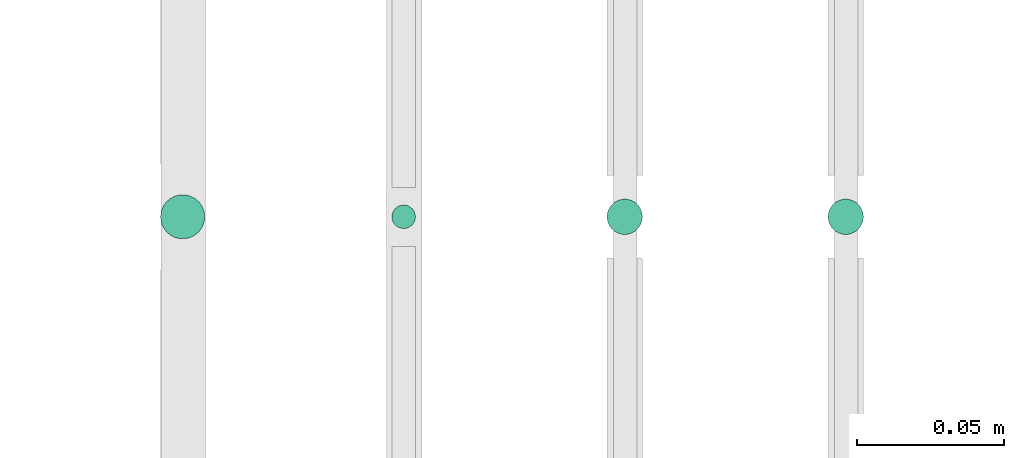
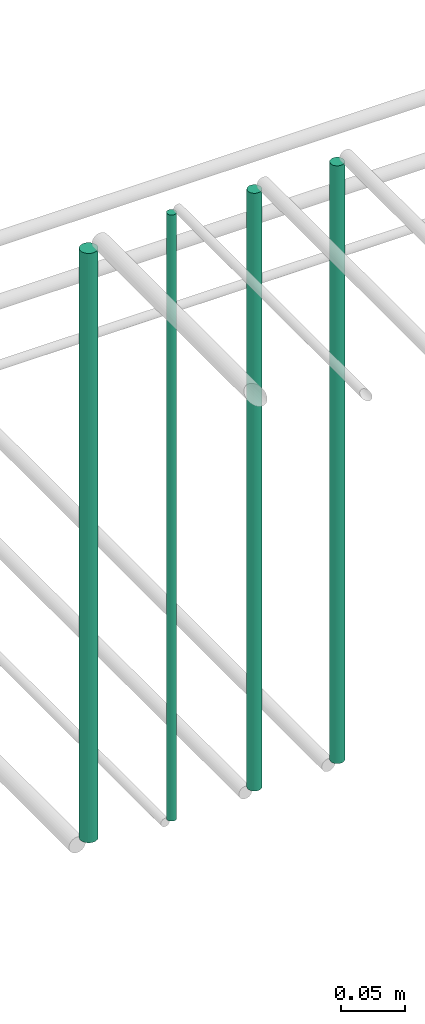
# One storey, part 123 of 331: 4 flow segments.
"""IFC2X3 building model written with IfcOpenShell, lengths in millimetres."""

import ifcopenshell
import ifcopenshell.guid

model = None  # the IFC model being written
_history = None  # IfcOwnerHistory: only IFC2X3 demands one
_inside = {}  # id of a spatial element -> (the spatial element, [elements in it])
_under = {}  # id of a project, library or spatial element -> (it, [spatial elements below it])
_declared = {}  # id of a project -> (the project, [libraries it declares])
_typed = {}  # id of a type object -> (the type object, [elements of that type])
_made_of = {}  # id of a material, layer set ... -> (it, [elements and type objects made of it])


def new_model(schema):
    """Start an empty IFC model of exactly this schema.

    Asked for "IFC4X3", IfcOpenShell would pick the latest addendum, in which some entities
    have other attributes; the version numbers below select the first issue.
    IFC2X3 requires an IfcOwnerHistory on every rooted entity: one is made here for all.
    """
    global model, _history
    if schema == "IFC4X3":
        model = ifcopenshell.file(schema_version=(4, 3, 0, 0))
    else:
        model = ifcopenshell.file(schema=schema)
    _inside.clear()
    _under.clear()
    _declared.clear()
    _typed.clear()
    _made_of.clear()
    _history = None
    if model.schema == "IFC2X3":
        org = make("IfcOrganization", Name="unknown")
        user = make(
            "IfcPersonAndOrganization",
            ThePerson=make("IfcPerson", FamilyName="unknown"),
            TheOrganization=org,
        )
        app = make(
            "IfcApplication",
            ApplicationDeveloper=org,
            Version="unknown",
            ApplicationFullName="unknown",
            ApplicationIdentifier="unknown",
        )
        _history = make(
            "IfcOwnerHistory",
            OwningUser=user,
            OwningApplication=app,
            ChangeAction="ADDED",
            CreationDate=0,
        )
    return model


def make(cls, **values):
    """One entity of the class cls with the attributes given. An attribute that is None is left unset."""
    return model.create_entity(
        cls, **{name: value for name, value in values.items() if value is not None}
    )


def entity(cls, *values):
    """Any entity or typed value of the class cls, its attributes in the order of the schema. None: left unset."""
    e = model.create_entity(cls)
    for i, value in enumerate(values):
        if value is not None:
            e[i] = value
    return e


def rooted(cls, **values):
    """An entity with a GlobalId (a new one), such as an element, a storey or a relation."""
    return make(cls, GlobalId=ifcopenshell.guid.new(), OwnerHistory=_history, **values)


def si_unit(unit_type, name, prefix=None):
    """IfcSIUnit, for example si_unit("LENGTHUNIT", "METRE", prefix="MILLI")."""
    return make("IfcSIUnit", UnitType=unit_type, Prefix=prefix, Name=name)


def converted_unit(unit_type, name, factor, base, dimensions=None, offset=None):
    """IfcConversionBasedUnit, such as the inch: factor (a typed value) times the base unit."""
    return make(
        "IfcConversionBasedUnit"
        if offset is None
        else "IfcConversionBasedUnitWithOffset",
        ConversionOffset=offset,
        Dimensions=None
        if dimensions is None
        else entity("IfcDimensionalExponents", *dimensions),
        UnitType=unit_type,
        Name=name,
        ConversionFactor=make(
            "IfcMeasureWithUnit", ValueComponent=factor, UnitComponent=base
        ),
    )


def derived_unit(unit_type, elements):
    """IfcDerivedUnit: a product of units, each with its exponent."""
    return make(
        "IfcDerivedUnit",
        Elements=[
            make("IfcDerivedUnitElement", Unit=unit, Exponent=power)
            for unit, power in elements
        ],
        UnitType=unit_type,
    )


def assignment(units):
    """IfcUnitAssignment: the units of a project."""
    return None if units is None else make("IfcUnitAssignment", Units=units)


def point(xyz):
    """IfcCartesianPoint."""
    return None if xyz is None else make("IfcCartesianPoint", Coordinates=xyz)


def direction(xyz):
    """IfcDirection."""
    return None if xyz is None else make("IfcDirection", DirectionRatios=xyz)


def frame(location, z_axis=None, x_axis=None):
    """IfcAxis2Placement3D, a coordinate frame: its origin and axes. An axis left out is left unset."""
    return make(
        "IfcAxis2Placement3D",
        Location=point(location),
        Axis=direction(z_axis),
        RefDirection=direction(x_axis),
    )


def frame_2d(location, x_axis=None):
    """IfcAxis2Placement2D, a coordinate frame in the plane: its origin and x axis."""
    return make(
        "IfcAxis2Placement2D", Location=point(location), RefDirection=direction(x_axis)
    )


def origin():
    """The frame at (0, 0, 0) with its axes left unset."""
    return frame((0.0, 0.0, 0.0))


def origin_2d_with_axis():
    """The frame at (0, 0) in the plane with the x axis (1, 0) written out."""
    return frame_2d((0.0, 0.0), x_axis=(1.0, 0.0))


def place(relative_to, where):
    """IfcLocalPlacement: puts the frame where relative to a parent placement (None: the world)."""
    return make(
        "IfcLocalPlacement", PlacementRelTo=relative_to, RelativePlacement=where
    )


def context(
    kind, dimensions, precision=None, world=None, true_north=None, identifier=None
):
    """IfcGeometricRepresentationContext, for example the 3D "Model" context."""
    return make(
        "IfcGeometricRepresentationContext",
        ContextIdentifier=identifier,
        ContextType=kind,
        CoordinateSpaceDimension=dimensions,
        Precision=precision,
        WorldCoordinateSystem=world,
        TrueNorth=true_north,
    )


def subcontext(parent, identifier, kind, view, scale=None):
    """IfcGeometricRepresentationSubContext, for example "Body" below "Model"."""
    return make(
        "IfcGeometricRepresentationSubContext",
        ContextIdentifier=identifier,
        ContextType=kind,
        ParentContext=parent,
        TargetScale=scale,
        TargetView=view,
    )


def project(units=None, contexts=None):
    """IfcProject with its units and contexts."""
    return rooted(
        "IfcProject",
        Name="project",
        RepresentationContexts=contexts,
        UnitsInContext=assignment(units),
    )


def spatial(cls, under=None, at=None, **own):
    """A site, building, storey or space (cls), placed at a placement, below another one or the project."""
    s = rooted(cls, ObjectPlacement=at, **own)
    if under is not None:
        _under.setdefault(under.id(), (under, []))[1].append(s)
    return s


def profile(cls, at=None, kind="AREA", **sizes):
    """A parametric profile (cls). Its sizes go by their IFC names, for example OverallWidth=200.0."""
    return make(cls, ProfileType=kind, Position=at, **sizes)


def circle(**sizes):
    """IfcCircleProfileDef."""
    return profile("IfcCircleProfileDef", **sizes)


def extrude(swept, where, along, depth):
    """IfcExtrudedAreaSolid: the profile swept, set in the frame where, extruded along a direction by depth."""
    return make(
        "IfcExtrudedAreaSolid",
        SweptArea=swept,
        Position=where,
        ExtrudedDirection=direction(along),
        Depth=depth,
    )


def shape(context_of_items, identifier, shape_type, items):
    """IfcShapeRepresentation: the items that make up one representation, for example the "Body"."""
    return make(
        "IfcShapeRepresentation",
        ContextOfItems=context_of_items,
        RepresentationIdentifier=identifier,
        RepresentationType=shape_type,
        Items=items,
    )


def made_of(thing, what):
    """Note that an element or type object is made of a material, layer set ...; save() writes the relation."""
    if what is not None:
        _made_of.setdefault(what.id(), (what, []))[1].append(thing)
    return thing


def type_object(cls, material=None, **own):
    """A type object (cls), such as IfcWallType, which elements share."""
    return made_of(rooted(cls, **own), material)


def element(
    cls,
    number,
    at=None,
    inside=None,
    cuts=None,
    type_object=None,
    material=None,
    context=None,
    identifier="Body",
    shape_type=None,
    held_by="IfcProductDefinitionShape",
    body=None,
    shapes=None,
    **own,
):
    """One element of the class cls, such as IfcWall. Its Tag is "e" and its number.

    at: its placement. inside: the storey or other place that contains it. cuts: it is an
    opening in that element (IfcRelVoidsElement). A single representation is given by context,
    identifier, shape_type and body (its items); several are given by shapes. held_by: the class
    of the entity that holds the representations. save() writes the other relations.
    """
    e = rooted(cls, Tag="e%d" % number, ObjectPlacement=at, **own)
    if body is not None:
        shapes = [shape(context, identifier, shape_type, body)]
    if shapes is not None:
        e.Representation = make(held_by, Representations=shapes)
    if inside is not None:
        _inside.setdefault(inside.id(), (inside, []))[1].append(e)
    if cuts is not None:
        rooted(
            "IfcRelVoidsElement", RelatingBuildingElement=cuts, RelatedOpeningElement=e
        )
    if type_object is not None:
        _typed.setdefault(type_object.id(), (type_object, []))[1].append(e)
    return made_of(e, material)


def aggregate(whole, parts):
    """IfcRelAggregates: a whole, such as a stair, and the parts it consists of."""
    return rooted("IfcRelAggregates", RelatingObject=whole, RelatedObjects=parts)


def save(model, path):
    """Write the relations noted so far, then the file.

    IfcRelAggregates (storeys below a building ...), IfcRelContainedInSpatialStructure (elements
    in a storey), IfcRelDefinesByType, IfcRelAssociatesMaterial and IfcRelDeclares: one each for
    every whole, place, type object, material and project.
    """
    for whole, parts in _under.values():
        aggregate(whole, parts)
    for where, things in _inside.values():
        rooted(
            "IfcRelContainedInSpatialStructure",
            RelatedElements=things,
            RelatingStructure=where,
        )
    for kind, things in _typed.values():
        rooted("IfcRelDefinesByType", RelatedObjects=things, RelatingType=kind)
    for what, things in _made_of.values():
        rooted("IfcRelAssociatesMaterial", RelatedObjects=things, RelatingMaterial=what)
    for by, libraries in _declared.values():
        rooted("IfcRelDeclares", RelatingContext=by, RelatedDefinitions=libraries)
    model.write(path)


model = new_model("IFC2X3")

# Units and contexts
model_context = context("Model", 3, precision=0.01, world=origin(), true_north=direction((6.12303176911189e-17, 1.0)))
body_context = subcontext(model_context, "Body", "Model", "MODEL_VIEW")
ifc_project = project(units=[si_unit("LENGTHUNIT", "METRE", prefix="MILLI"), si_unit("AREAUNIT", "SQUARE_METRE"), si_unit("VOLUMEUNIT", "CUBIC_METRE"), converted_unit("PLANEANGLEUNIT", "DEGREE", entity("IfcRatioMeasure", 0.0174532925199433), si_unit("PLANEANGLEUNIT", "RADIAN"), dimensions=[0, 0, 0, 0, 0, 0, 0]), si_unit("MASSUNIT", "GRAM", prefix="KILO"), derived_unit("MASSDENSITYUNIT", [(si_unit("MASSUNIT", "GRAM", prefix="KILO"), 1), (si_unit("LENGTHUNIT", "METRE"), -3)]), derived_unit("MOMENTOFINERTIAUNIT", [(si_unit("LENGTHUNIT", "METRE"), 4)]), si_unit("TIMEUNIT", "SECOND"), si_unit("FREQUENCYUNIT", "HERTZ"), si_unit("THERMODYNAMICTEMPERATUREUNIT", "DEGREE_CELSIUS"), derived_unit("THERMALTRANSMITTANCEUNIT", [(si_unit("MASSUNIT", "GRAM", prefix="KILO"), 1), (si_unit("THERMODYNAMICTEMPERATUREUNIT", "KELVIN"), -1), (si_unit("TIMEUNIT", "SECOND"), -3)]), derived_unit("VOLUMETRICFLOWRATEUNIT", [(si_unit("LENGTHUNIT", "METRE"), 3), (si_unit("TIMEUNIT", "SECOND"), -1)]), derived_unit("MASSFLOWRATEUNIT", [(si_unit("MASSUNIT", "GRAM", prefix="KILO"), 1), (si_unit("TIMEUNIT", "SECOND"), -1)]), derived_unit("ROTATIONALFREQUENCYUNIT", [(si_unit("TIMEUNIT", "SECOND"), -1)]), si_unit("ELECTRICCURRENTUNIT", "AMPERE"), si_unit("ELECTRICVOLTAGEUNIT", "VOLT"), si_unit("POWERUNIT", "WATT"), si_unit("FORCEUNIT", "NEWTON", prefix="KILO"), si_unit("ILLUMINANCEUNIT", "LUX"), si_unit("LUMINOUSFLUXUNIT", "LUMEN"), si_unit("LUMINOUSINTENSITYUNIT", "CANDELA"), derived_unit("USERDEFINED", [(si_unit("MASSUNIT", "GRAM", prefix="KILO"), -1), (si_unit("LENGTHUNIT", "METRE"), -2), (si_unit("TIMEUNIT", "SECOND"), 3), (si_unit("LUMINOUSFLUXUNIT", "LUMEN"), 1)]), derived_unit("LINEARVELOCITYUNIT", [(si_unit("LENGTHUNIT", "METRE"), 1), (si_unit("TIMEUNIT", "SECOND"), -1)]), si_unit("PRESSUREUNIT", "PASCAL"), derived_unit("USERDEFINED", [(si_unit("LENGTHUNIT", "METRE"), -2), (si_unit("MASSUNIT", "GRAM", prefix="KILO"), 1), (si_unit("TIMEUNIT", "SECOND"), -2)]), derived_unit("LINEARFORCEUNIT", [(si_unit("MASSUNIT", "GRAM", prefix="KILO"), 1), (si_unit("LENGTHUNIT", "METRE"), 1), (si_unit("TIMEUNIT", "SECOND"), -2), (si_unit("LENGTHUNIT", "METRE"), -1)]), derived_unit("PLANARFORCEUNIT", [(si_unit("MASSUNIT", "GRAM", prefix="KILO"), 1), (si_unit("LENGTHUNIT", "METRE"), 1), (si_unit("TIMEUNIT", "SECOND"), -2), (si_unit("LENGTHUNIT", "METRE"), -2)])], contexts=[model_context])

# Site, building, storey
site_placement = place(None, frame((0.0, -0.00077364408347762, 0.0)))
site = spatial("IfcSite", under=ifc_project, at=site_placement, CompositionType="ELEMENT")
building_placement = place(site_placement, origin())
building = spatial("IfcBuilding", under=site, at=building_placement, CompositionType="ELEMENT")
storey_placement = place(building_placement, origin())
storey = spatial("IfcBuildingStorey", under=building, at=storey_placement, CompositionType="ELEMENT", Elevation=0.0)

# Flow segments
pipe_segment_type = type_object("IfcPipeSegmentType", PredefinedType="NOTDEFINED")
flow_segment_1_placement = place(storey_placement, frame((20838.5132627125, 5536.0252915914, 14564.0)))
element("IfcFlowSegment", 1, at=flow_segment_1_placement, inside=storey, type_object=pipe_segment_type, context=body_context, shape_type="SweptSolid", body=[
    extrude(circle(Radius=6.0, at=origin_2d_with_axis()), frame((7.59527223591454, 7.59527223591562, 0.0), z_axis=(0.0, 0.0, 1.0), x_axis=(-1.0, 0.0, 0.0)), (0.0, 0.0, 1.0), 572.000000000019),
])
flow_segment_2_placement = place(storey_placement, frame((20763.5132627125, 5536.0252915914, 14564.0)))
element("IfcFlowSegment", 2, at=flow_segment_2_placement, inside=storey, type_object=pipe_segment_type, context=body_context, shape_type="SweptSolid", body=[
    extrude(circle(Radius=6.0, at=origin_2d_with_axis()), frame((7.59527223591454, 7.59527223591562, 0.0), z_axis=(0.0, 0.0, 1.0), x_axis=(-1.0, 0.0, 0.0)), (0.0, 0.0, 1.0), 572.0),
])
flow_segment_3_placement = place(storey_placement, frame((20690.5132627125, 5538.0252915914, 14560.0)))
element("IfcFlowSegment", 3, at=flow_segment_3_placement, inside=storey, type_object=pipe_segment_type, context=body_context, shape_type="SweptSolid", body=[
    extrude(circle(Radius=4.0, at=origin_2d_with_axis()), frame((5.59527223591499, 5.59527223591607, 0.0), z_axis=(0.0, 0.0, 1.0), x_axis=(-1.0, 0.0, 0.0)), (0.0, 0.0, 1.0), 580.0),
])
flow_segment_4_placement = place(storey_placement, frame((20612.0132627125, 5534.5252915914, 14568.0)))
element("IfcFlowSegment", 4, at=flow_segment_4_placement, inside=storey, type_object=pipe_segment_type, context=body_context, shape_type="SweptSolid", body=[
    extrude(circle(Radius=7.5, at=origin_2d_with_axis()), frame((9.09527223591419, 9.09527223591636, 0.0), z_axis=(0.0, 0.0, 1.0), x_axis=(-1.0, 0.0, 0.0)), (0.0, 0.0, 1.0), 564.000000000034),
])

save(model, "model.ifc")
